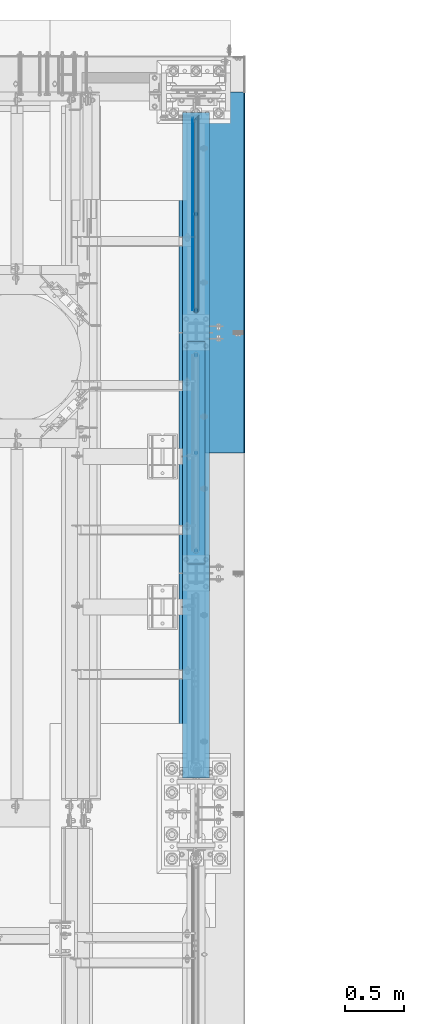
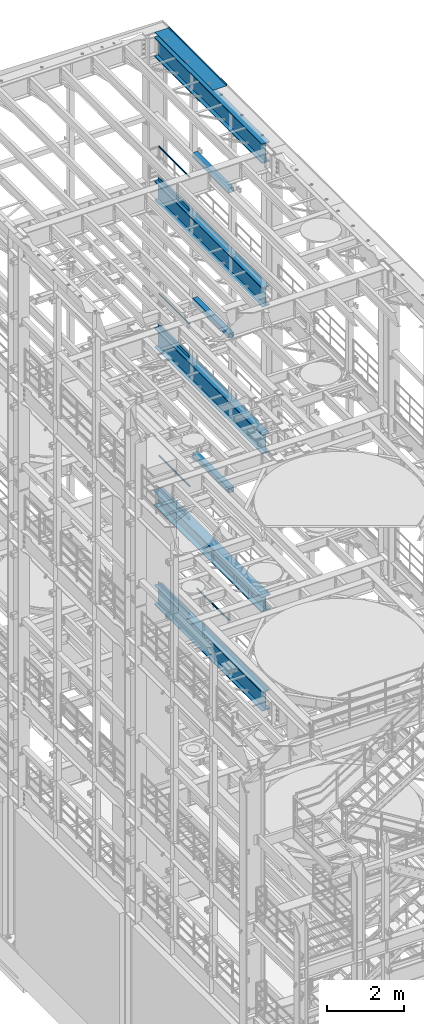
# One storey, part 1078 of 1876: 17 beams, 14 elements without a shape of their own.
"""IFC2X3 building model written with IfcOpenShell, lengths in millimetres."""

from ifc_helpers import new_model, si_unit, frame, origin_with_axes, place, context, subcontext, project, spatial, faceted_brep, material, type_object, element, aggregate, save


model = new_model("IFC2X3")

# Units and contexts
model_context = context("Model", 3, precision=1e-05, world=origin_with_axes())
body_context = subcontext(model_context, "Body", "Model", "MODEL_VIEW")
ifc_project = project(units=[si_unit("LENGTHUNIT", "METRE", prefix="MILLI"), si_unit("AREAUNIT", "SQUARE_METRE"), si_unit("VOLUMEUNIT", "CUBIC_METRE"), si_unit("MASSUNIT", "GRAM", prefix="KILO"), si_unit("TIMEUNIT", "SECOND"), si_unit("PLANEANGLEUNIT", "RADIAN"), si_unit("SOLIDANGLEUNIT", "STERADIAN"), si_unit("THERMODYNAMICTEMPERATUREUNIT", "DEGREE_CELSIUS"), si_unit("LUMINOUSINTENSITYUNIT", "LUMEN")], contexts=[model_context])

# Site, building, storey
site_placement = place(None, origin_with_axes())
site = spatial("IfcSite", under=ifc_project, at=site_placement, CompositionType="ELEMENT")
building_placement = place(site_placement, origin_with_axes())
building = spatial("IfcBuilding", under=site, at=building_placement, Name="Undefined", CompositionType="ELEMENT")
storey_placement = place(building_placement, origin_with_axes())
storey = spatial("IfcBuildingStorey", under=building, at=storey_placement, Name="Undefined", CompositionType="ELEMENT", Elevation=0.0)

# Assembly, beam
assembly_1_placement = place(storey_placement, origin_with_axes())
assembly_1 = element("IfcElementAssembly", 1, at=assembly_1_placement, inside=storey, Name="RAIL", AssemblyPlace="NOTDEFINED", PredefinedType="RIGID_FRAME")
ifc_material_1 = material()
beam_type_1 = type_object("IfcBeamType", Name="PIPE1-1/2SCH40", PredefinedType="NOTDEFINED")
beam_1_placement = place(assembly_1_placement, frame((7619.99999999998, 11848.7825, 19059.525), z_axis=(0.0, 0.0, -1.0), x_axis=(0.0, 1.0, 0.0)))
beam_1 = element("IfcBeam", 2, at=beam_1_placement, type_object=beam_type_1, material=ifc_material_1, Name="RAIL", ObjectType="PIPE1-1/2SCH40", context=body_context, shape_type="Brep", body=[
    faceted_brep([(24.1300000000001, -20.4469999999999, 0.0), (34.3535000000002, -17.7076214311803, 10.2235000000001), (1633.21617856882, -17.7076214311801, 10.2235000000001), (1630.4768, -20.4470000000001, 0.0), (41.8376214311802, -10.2235000000001, 17.7076214311819), (1640.7003, -10.2235000000001, 17.7076214311819), (44.5770000000002, 0.0, 20.4470000000001), (1650.9238, 0.0, 20.4470000000001), (41.8376214311802, 10.2235000000001, 17.7076214311819), (1661.1473, 10.2235000000001, 17.7076214311819), (34.3535000000002, 17.7076214311803, 10.2235000000001), (1668.63142143118, 17.7076214311801, 10.2235000000001), (24.1300000000001, 20.4469999999999, 0.0), (1671.3708, 20.4470000000001, 0.0), (13.9065000000001, 17.7076214311803, -10.2235000000001), (1668.63142143118, 17.7076214311801, -10.2235000000001), (6.42237856882002, 10.2235000000001, -17.7076214311819), (1661.1473, 10.2235000000001, -17.7076214311819), (3.68299999999999, 0.0, -20.4470000000001), (1650.9238, 0.0, -20.4470000000001), (6.42237856882002, -10.2235000000001, -17.7076214311819), (1640.7003, -10.2235000000001, -17.7076214311819), (13.9065000000001, -17.7076214311803, -10.2235000000001), (1633.21617856882, -17.7076214311801, -10.2235000000001), (24.1299999999854, -24.1299999999992, 0.0), (12.0650000000064, -20.8971929933177, -12.0649999999987), (1630.02660700668, -20.8971929933186, -12.0649999999987), (1626.7938, -24.1300000000001, 0.0), (3.23280700668147, -12.0650000000001, -20.8971929933177), (1638.8588, -12.0649999999996, -20.8971929933177), (-1.45519152283669e-11, 0.0, -24.130000000001), (1650.9238, 0.0, -24.130000000001), (3.23280700668147, 12.0650000000001, -20.8971929933177), (1662.9888, 12.0649999999996, -20.8971929933177), (12.0650000000064, 20.8971929933177, -12.0649999999987), (1671.82099299332, 20.8971929933186, -12.0649999999987), (24.1300000000047, 24.1299999999992, 0.0), (1675.0538, 24.1300000000001, 0.0), (36.1949999999997, 20.8971929933184, 12.0649999999987), (1671.82099299332, 20.8971929933186, 12.0649999999987), (45.0271929933187, 12.0650000000001, 20.8971929933177), (1662.9888, 12.0649999999996, 20.8971929933177), (48.2600000000002, 0.0, 24.130000000001), (1650.9238, 0.0, 24.130000000001), (45.0271929933187, -12.0650000000001, 20.8971929933177), (1638.8588, -12.0649999999996, 20.8971929933177), (36.1949999999997, -20.8971929933184, 12.0649999999987), (1630.02660700668, -20.8971929933186, 12.0649999999987)], [[[0, 1, 2, 3]], [[1, 4, 5, 2]], [[4, 6, 7, 5]], [[6, 8, 9, 7]], [[8, 10, 11, 9]], [[10, 12, 13, 11]], [[12, 14, 15, 13]], [[14, 16, 17, 15]], [[16, 18, 19, 17]], [[18, 20, 21, 19]], [[20, 22, 23, 21]], [[22, 0, 3, 23]], [[24, 25, 26, 27]], [[25, 28, 29, 26]], [[28, 30, 31, 29]], [[30, 32, 33, 31]], [[32, 34, 35, 33]], [[34, 36, 37, 35]], [[36, 38, 39, 37]], [[38, 40, 41, 39]], [[40, 42, 43, 41]], [[42, 44, 45, 43]], [[44, 46, 47, 45]], [[46, 24, 27, 47]], [[29, 31, 33, 35, 37, 39, 41, 43, 45, 47, 27, 26], [5, 7, 9, 11, 13, 15, 17, 19, 21, 23, 3, 2]], [[46, 44, 42, 40, 38, 36, 34, 32, 30, 28, 25, 24], [22, 20, 18, 16, 14, 12, 10, 8, 6, 4, 1, 0]]]),
])

assembly_2_placement = place(storey_placement, origin_with_axes())
assembly_2 = element("IfcElementAssembly", 3, at=assembly_2_placement, inside=storey, Name="RAIL", AssemblyPlace="NOTDEFINED", PredefinedType="RIGID_FRAME")
beam_2_placement = place(assembly_2_placement, frame((7619.99999999997, 11848.7825, 14385.925), z_axis=(0.0, 0.0, -1.0), x_axis=(0.0, 1.0, 0.0)))
beam_2 = element("IfcBeam", 4, at=beam_2_placement, type_object=beam_type_1, material=ifc_material_1, Name="RAIL", ObjectType="PIPE1-1/2SCH40", context=body_context, shape_type="Brep", body=[
    faceted_brep([(24.1300000000001, -20.4469999999999, 0.0), (34.3535000000002, -17.7076214311803, 10.2235000000001), (1633.21617856882, -17.7076214311801, 10.2235000000001), (1630.4768, -20.4470000000001, 0.0), (41.8376214311802, -10.2235000000001, 17.7076214311819), (1640.7003, -10.2235000000001, 17.7076214311819), (44.5770000000002, 0.0, 20.4470000000001), (1650.9238, 0.0, 20.4470000000001), (41.8376214311802, 10.2235000000001, 17.7076214311819), (1661.1473, 10.2235000000001, 17.7076214311819), (34.3535000000002, 17.7076214311803, 10.2235000000001), (1668.63142143118, 17.7076214311801, 10.2235000000001), (24.1300000000001, 20.4469999999999, 0.0), (1671.3708, 20.4470000000001, 0.0), (13.9065000000001, 17.7076214311803, -10.2235000000001), (1668.63142143118, 17.7076214311801, -10.2235000000001), (6.42237856882002, 10.2235000000001, -17.7076214311819), (1661.1473, 10.2235000000001, -17.7076214311819), (3.68299999999999, 0.0, -20.4470000000001), (1650.9238, 0.0, -20.4470000000001), (6.42237856882002, -10.2235000000001, -17.7076214311819), (1640.7003, -10.2235000000001, -17.7076214311819), (13.9065000000001, -17.7076214311803, -10.2235000000001), (1633.21617856882, -17.7076214311801, -10.2235000000001), (24.1299999999854, -24.1299999999992, 0.0), (12.0650000000064, -20.8971929933177, -12.0649999999987), (1630.02660700668, -20.8971929933186, -12.0649999999987), (1626.7938, -24.1300000000001, 0.0), (3.23280700668147, -12.0650000000001, -20.8971929933177), (1638.8588, -12.0649999999996, -20.8971929933177), (-1.45519152283669e-11, 0.0, -24.130000000001), (1650.9238, 0.0, -24.130000000001), (3.23280700668147, 12.0650000000001, -20.8971929933177), (1662.9888, 12.0649999999996, -20.8971929933177), (12.0650000000064, 20.8971929933177, -12.0649999999987), (1671.82099299332, 20.8971929933186, -12.0649999999987), (24.1300000000047, 24.1299999999992, 0.0), (1675.0538, 24.1300000000001, 0.0), (36.1949999999997, 20.8971929933184, 12.0649999999987), (1671.82099299332, 20.8971929933186, 12.0649999999987), (45.0271929933187, 12.0650000000001, 20.8971929933177), (1662.9888, 12.0649999999996, 20.8971929933177), (48.2600000000002, 0.0, 24.130000000001), (1650.9238, 0.0, 24.130000000001), (45.0271929933187, -12.0650000000001, 20.8971929933177), (1638.8588, -12.0649999999996, 20.8971929933177), (36.1949999999997, -20.8971929933184, 12.0649999999987), (1630.02660700668, -20.8971929933186, 12.0649999999987)], [[[0, 1, 2, 3]], [[1, 4, 5, 2]], [[4, 6, 7, 5]], [[6, 8, 9, 7]], [[8, 10, 11, 9]], [[10, 12, 13, 11]], [[12, 14, 15, 13]], [[14, 16, 17, 15]], [[16, 18, 19, 17]], [[18, 20, 21, 19]], [[20, 22, 23, 21]], [[22, 0, 3, 23]], [[24, 25, 26, 27]], [[25, 28, 29, 26]], [[28, 30, 31, 29]], [[30, 32, 33, 31]], [[32, 34, 35, 33]], [[34, 36, 37, 35]], [[36, 38, 39, 37]], [[38, 40, 41, 39]], [[40, 42, 43, 41]], [[42, 44, 45, 43]], [[44, 46, 47, 45]], [[46, 24, 27, 47]], [[29, 31, 33, 35, 37, 39, 41, 43, 45, 47, 27, 26], [5, 7, 9, 11, 13, 15, 17, 19, 21, 23, 3, 2]], [[46, 44, 42, 40, 38, 36, 34, 32, 30, 28, 25, 24], [22, 20, 18, 16, 14, 12, 10, 8, 6, 4, 1, 0]]]),
])

assembly_3_placement = place(storey_placement, origin_with_axes())
assembly_3 = element("IfcElementAssembly", 5, at=assembly_3_placement, inside=storey, Name="RAIL", AssemblyPlace="NOTDEFINED", PredefinedType="RIGID_FRAME")
beam_3_placement = place(assembly_3_placement, frame((7619.99999999997, 11848.7825, 9229.725), z_axis=(0.0, 0.0, -1.0), x_axis=(0.0, 1.0, 0.0)))
beam_3 = element("IfcBeam", 6, at=beam_3_placement, type_object=beam_type_1, material=ifc_material_1, Name="RAIL", ObjectType="PIPE1-1/2SCH40", context=body_context, shape_type="Brep", body=[
    faceted_brep([(24.1300000000001, -20.4469999999999, 0.0), (34.3535000000002, -17.7076214311803, 10.2235000000001), (1633.21617856882, -17.7076214311801, 10.2235000000001), (1630.4768, -20.4470000000001, 0.0), (41.8376214311802, -10.2235000000001, 17.7076214311819), (1640.7003, -10.2235000000001, 17.7076214311819), (44.5770000000002, 0.0, 20.4470000000001), (1650.9238, 0.0, 20.4470000000001), (41.8376214311802, 10.2235000000001, 17.7076214311819), (1661.1473, 10.2235000000001, 17.7076214311819), (34.3535000000002, 17.7076214311803, 10.2235000000001), (1668.63142143118, 17.7076214311801, 10.2235000000001), (24.1300000000001, 20.4469999999999, 0.0), (1671.3708, 20.4470000000001, 0.0), (13.9065000000001, 17.7076214311803, -10.2235000000001), (1668.63142143118, 17.7076214311801, -10.2235000000001), (6.42237856882002, 10.2235000000001, -17.7076214311819), (1661.1473, 10.2235000000001, -17.7076214311819), (3.68299999999999, 0.0, -20.4470000000001), (1650.9238, 0.0, -20.4470000000001), (6.42237856882002, -10.2235000000001, -17.7076214311819), (1640.7003, -10.2235000000001, -17.7076214311819), (13.9065000000001, -17.7076214311803, -10.2235000000001), (1633.21617856882, -17.7076214311801, -10.2235000000001), (24.1299999999854, -24.1299999999992, 0.0), (12.0650000000064, -20.8971929933177, -12.0649999999987), (1630.02660700668, -20.8971929933186, -12.0649999999987), (1626.7938, -24.1300000000001, 0.0), (3.23280700668147, -12.0650000000001, -20.8971929933177), (1638.8588, -12.0649999999996, -20.8971929933177), (-1.45519152283669e-11, 0.0, -24.130000000001), (1650.9238, 0.0, -24.130000000001), (3.23280700668147, 12.0650000000001, -20.8971929933177), (1662.9888, 12.0649999999996, -20.8971929933177), (12.0650000000064, 20.8971929933177, -12.0649999999987), (1671.82099299332, 20.8971929933186, -12.0649999999987), (24.1300000000047, 24.1299999999992, 0.0), (1675.0538, 24.1300000000001, 0.0), (36.1949999999997, 20.8971929933184, 12.0649999999987), (1671.82099299332, 20.8971929933186, 12.0649999999987), (45.0271929933187, 12.0650000000001, 20.8971929933177), (1662.9888, 12.0649999999996, 20.8971929933177), (48.2600000000002, 0.0, 24.130000000001), (1650.9238, 0.0, 24.130000000001), (45.0271929933187, -12.0650000000001, 20.8971929933177), (1638.8588, -12.0649999999996, 20.8971929933177), (36.1949999999997, -20.8971929933184, 12.0649999999987), (1630.02660700668, -20.8971929933186, 12.0649999999987)], [[[0, 1, 2, 3]], [[1, 4, 5, 2]], [[4, 6, 7, 5]], [[6, 8, 9, 7]], [[8, 10, 11, 9]], [[10, 12, 13, 11]], [[12, 14, 15, 13]], [[14, 16, 17, 15]], [[16, 18, 19, 17]], [[18, 20, 21, 19]], [[20, 22, 23, 21]], [[22, 0, 3, 23]], [[24, 25, 26, 27]], [[25, 28, 29, 26]], [[28, 30, 31, 29]], [[30, 32, 33, 31]], [[32, 34, 35, 33]], [[34, 36, 37, 35]], [[36, 38, 39, 37]], [[38, 40, 41, 39]], [[40, 42, 43, 41]], [[42, 44, 45, 43]], [[44, 46, 47, 45]], [[46, 24, 27, 47]], [[29, 31, 33, 35, 37, 39, 41, 43, 45, 47, 27, 26], [5, 7, 9, 11, 13, 15, 17, 19, 21, 23, 3, 2]], [[46, 44, 42, 40, 38, 36, 34, 32, 30, 28, 25, 24], [22, 20, 18, 16, 14, 12, 10, 8, 6, 4, 1, 0]]]),
])

assembly_4_placement = place(storey_placement, origin_with_axes())
assembly_4 = element("IfcElementAssembly", 7, at=assembly_4_placement, inside=storey, Name="RAIL", AssemblyPlace="NOTDEFINED", PredefinedType="RIGID_FRAME")
beam_4_placement = place(assembly_4_placement, frame((7620.0, 9817.1, 6207.125), z_axis=(0.0, 0.0, -1.0), x_axis=(0.0, 1.0, 0.0)))
beam_4 = element("IfcBeam", 8, at=beam_4_placement, type_object=beam_type_1, material=ifc_material_1, Name="RAIL", ObjectType="PIPE1-1/2SCH40", context=body_context, shape_type="Brep", body=[
    faceted_brep([(24.1300000000001, -20.4469999999999, 0.0), (34.3535000000002, -17.7076214311803, 10.2235000000001), (1667.4465, -17.7076214311801, 10.2235000000001), (1677.67, -20.4470000000001, 0.0), (41.8376214311802, -10.2235000000001, 17.7076214311819), (1659.96237856882, -10.2235000000001, 17.7076214311819), (44.5770000000002, 0.0, 20.4470000000001), (1657.223, 0.0, 20.4470000000001), (41.8376214311802, 10.2235000000001, 17.7076214311819), (1659.96237856882, 10.2235000000001, 17.7076214311819), (34.3535000000002, 17.7076214311803, 10.2235000000001), (1667.4465, 17.7076214311801, 10.2235000000001), (24.1300000000001, 20.4469999999999, 0.0), (1677.67, 20.4470000000001, 0.0), (13.9065000000001, 17.7076214311803, -10.2235000000001), (1687.8935, 17.7076214311801, -10.2235000000001), (6.42237856882002, 10.2235000000001, -17.7076214311819), (1695.37762143118, 10.2235000000001, -17.7076214311819), (3.68299999999999, 0.0, -20.4470000000001), (1698.117, 0.0, -20.4470000000001), (6.42237856882002, -10.2235000000001, -17.7076214311819), (1695.37762143118, -10.2235000000001, -17.7076214311819), (13.9065000000001, -17.7076214311803, -10.2235000000001), (1687.8935, -17.7076214311801, -10.2235000000001), (24.1299999999854, -24.1299999999992, 0.0), (12.0650000000064, -20.8971929933177, -12.0649999999987), (1689.735, -20.8971929933186, -12.0649999999987), (1677.67, -24.1300000000001, 0.0), (3.23280700668147, -12.0650000000001, -20.8971929933177), (1698.56719299332, -12.0649999999996, -20.8971929933177), (-1.45519152283669e-11, 0.0, -24.130000000001), (1701.8, 0.0, -24.130000000001), (3.23280700668147, 12.0650000000001, -20.8971929933177), (1698.56719299332, 12.0649999999996, -20.8971929933177), (12.0650000000064, 20.8971929933177, -12.0649999999987), (1689.735, 20.8971929933186, -12.0649999999987), (24.1300000000047, 24.1299999999992, 0.0), (1677.67, 24.1300000000001, 0.0), (36.1949999999997, 20.8971929933184, 12.0649999999987), (1665.605, 20.8971929933186, 12.0649999999987), (45.0271929933187, 12.0650000000001, 20.8971929933177), (1656.77280700668, 12.0649999999996, 20.8971929933177), (48.2600000000002, 0.0, 24.130000000001), (1653.54, 0.0, 24.130000000001), (45.0271929933187, -12.0650000000001, 20.8971929933177), (1656.77280700668, -12.0649999999996, 20.8971929933177), (36.1949999999997, -20.8971929933184, 12.0649999999987), (1665.605, -20.8971929933186, 12.0649999999987)], [[[0, 1, 2, 3]], [[1, 4, 5, 2]], [[4, 6, 7, 5]], [[6, 8, 9, 7]], [[8, 10, 11, 9]], [[10, 12, 13, 11]], [[12, 14, 15, 13]], [[14, 16, 17, 15]], [[16, 18, 19, 17]], [[18, 20, 21, 19]], [[20, 22, 23, 21]], [[22, 0, 3, 23]], [[24, 25, 26, 27]], [[25, 28, 29, 26]], [[28, 30, 31, 29]], [[30, 32, 33, 31]], [[32, 34, 35, 33]], [[34, 36, 37, 35]], [[36, 38, 39, 37]], [[38, 40, 41, 39]], [[40, 42, 43, 41]], [[42, 44, 45, 43]], [[44, 46, 47, 45]], [[46, 24, 27, 47]], [[29, 31, 33, 35, 37, 39, 41, 43, 45, 47, 27, 26], [5, 7, 9, 11, 13, 15, 17, 19, 21, 23, 3, 2]], [[46, 44, 42, 40, 38, 36, 34, 32, 30, 28, 25, 24], [22, 20, 18, 16, 14, 12, 10, 8, 6, 4, 1, 0]]]),
])
aggregate(assembly_4, [beam_4])

assembly_5_placement = place(storey_placement, origin_with_axes())
assembly_5 = element("IfcElementAssembly", 9, at=assembly_5_placement, inside=storey, Name="BEAM", AssemblyPlace="NOTDEFINED", PredefinedType="RIGID_FRAME")
ifc_material_2 = material()
beam_type_2 = type_object("IfcBeamType", Name="HSS6X6X3/8", PredefinedType="NOTDEFINED")
beam_5_placement = place(assembly_5_placement, frame((7619.99999974511, 9652.0, 19958.05), z_axis=(-1.0, 0.0, 0.0), x_axis=(0.0, 1.0, 0.0)))
beam_5 = element("IfcBeam", 10, at=beam_5_placement, type_object=beam_type_2, material=ifc_material_2, Name="BEAM", ObjectType="HSS6X6X3/8", context=body_context, shape_type="Brep", body=[
    faceted_brep([(76.2000000000007, 66.6749999999993, -66.6750000000002), (76.2000000000007, -66.6749999999993, -66.6750000000002), (1955.8, -66.6749999999993, -66.675), (1955.8, 66.6749999999993, -66.675), (76.2000000000007, -66.6749999999993, 66.6750000000002), (1955.8, -66.6749999999993, 66.675), (76.2000000000007, 66.6749999999993, 66.6750000000002), (1955.8, 66.6749999999993, 66.675), (76.2000000000007, 76.2000000000007, -76.1999999999998), (76.2000000000007, 76.2000000000007, 76.1999999999998), (1955.8, 76.2000000000007, 76.2), (1955.8, 76.2000000000007, -76.2), (76.2000000000007, -76.2000000000007, 76.1999999999998), (1955.8, -76.2000000000007, 76.2), (76.2000000000007, -76.2000000000007, -76.1999999999998), (1955.8, -76.2000000000007, -76.2)], [[[0, 1, 2, 3]], [[1, 4, 5, 2]], [[4, 6, 7, 5]], [[6, 0, 3, 7]], [[8, 9, 10, 11]], [[9, 12, 13, 10]], [[12, 14, 15, 13]], [[14, 8, 11, 15]], [[13, 15, 11, 10], [5, 7, 3, 2]], [[14, 12, 9, 8], [6, 4, 1, 0]]]),
])
aggregate(assembly_5, [beam_5])

assembly_6_placement = place(storey_placement, origin_with_axes())
assembly_6 = element("IfcElementAssembly", 11, at=assembly_6_placement, inside=storey, Name="BEAM", AssemblyPlace="NOTDEFINED", PredefinedType="RIGID_FRAME")
beam_6_placement = place(assembly_6_placement, frame((7620.0, 9652.0, 15335.25), z_axis=(-1.0, 0.0, 0.0), x_axis=(0.0, 1.0, 0.0)))
beam_6 = element("IfcBeam", 12, at=beam_6_placement, type_object=beam_type_2, material=ifc_material_2, Name="BEAM", ObjectType="HSS6X6X3/8", context=body_context, shape_type="Brep", body=[
    faceted_brep([(76.2000000000007, 66.6749999999993, -66.6750000000002), (76.2000000000007, -66.6749999999993, -66.6750000000002), (1955.8, -66.6749999999993, -66.675), (1955.8, 66.6749999999993, -66.675), (76.2000000000007, -66.6749999999993, 66.6750000000002), (1955.8, -66.6749999999993, 66.675), (76.2000000000007, 66.6749999999993, 66.6750000000002), (1955.8, 66.6749999999993, 66.675), (76.2000000000007, 76.2000000000007, -76.1999999999998), (76.2000000000007, 76.2000000000007, 76.1999999999998), (1955.8, 76.2000000000007, 76.2), (1955.8, 76.2000000000007, -76.2), (76.2000000000007, -76.2000000000007, 76.1999999999998), (1955.8, -76.2000000000007, 76.2), (76.2000000000007, -76.2000000000007, -76.1999999999998), (1955.8, -76.2000000000007, -76.2)], [[[0, 1, 2, 3]], [[1, 4, 5, 2]], [[4, 6, 7, 5]], [[6, 0, 3, 7]], [[8, 9, 10, 11]], [[9, 12, 13, 10]], [[12, 14, 15, 13]], [[14, 8, 11, 15]], [[13, 15, 11, 10], [5, 7, 3, 2]], [[14, 12, 9, 8], [6, 4, 1, 0]]]),
])
aggregate(assembly_6, [beam_6])

assembly_7_placement = place(storey_placement, origin_with_axes())
assembly_7 = element("IfcElementAssembly", 13, at=assembly_7_placement, inside=storey, Name="BEAM", AssemblyPlace="NOTDEFINED", PredefinedType="RIGID_FRAME")
beam_7_placement = place(assembly_7_placement, frame((7620.0, 9652.0, 10420.35), z_axis=(-1.0, 0.0, 0.0), x_axis=(0.0, 1.0, 0.0)))
beam_7 = element("IfcBeam", 14, at=beam_7_placement, type_object=beam_type_2, material=ifc_material_2, Name="BEAM", ObjectType="HSS6X6X3/8", context=body_context, shape_type="Brep", body=[
    faceted_brep([(76.2000000000007, 66.6749999999993, -66.6750000000002), (76.2000000000007, -66.6749999999993, -66.6750000000002), (1955.8, -66.6749999999993, -66.675), (1955.8, 66.6749999999993, -66.675), (76.2000000000007, -66.6749999999993, 66.6750000000002), (1955.8, -66.6749999999993, 66.675), (76.2000000000007, 66.6749999999993, 66.6750000000002), (1955.8, 66.6749999999993, 66.675), (76.2000000000007, 76.2000000000007, -76.1999999999998), (76.2000000000007, 76.2000000000007, 76.1999999999998), (1955.8, 76.2000000000007, 76.2), (1955.8, 76.2000000000007, -76.2), (76.2000000000007, -76.2000000000007, 76.1999999999998), (1955.8, -76.2000000000007, 76.2), (76.2000000000007, -76.2000000000007, -76.1999999999998), (1955.8, -76.2000000000007, -76.2)], [[[0, 1, 2, 3]], [[1, 4, 5, 2]], [[4, 6, 7, 5]], [[6, 0, 3, 7]], [[8, 9, 10, 11]], [[9, 12, 13, 10]], [[12, 14, 15, 13]], [[14, 8, 11, 15]], [[13, 15, 11, 10], [5, 7, 3, 2]], [[14, 12, 9, 8], [6, 4, 1, 0]]]),
])
aggregate(assembly_7, [beam_7])

# Beam
ifc_material_3 = material(Name="STEEL/A36")
beam_type_3 = type_object("IfcBeamType", PredefinedType="NOTDEFINED")
beam_8_placement = place(assembly_1_placement, frame((7592.69500000001, 11872.9125, 18049.875), z_axis=(0.0, 0.0, 1.0), x_axis=(0.0, 1.0, 0.0)))
beam_8 = element("IfcBeam", 15, at=beam_8_placement, type_object=beam_type_3, material=ifc_material_3, Name="PLATE", context=body_context, shape_type="Brep", body=[
    faceted_brep([(0.0, 3.17500000000018, -50.8000000000002), (0.0, 3.17500000000018, 50.8000000000002), (1626.7938, 3.175, 50.7999999999993), (1626.7938, 3.175, -50.7999999999993), (0.0, -3.17500000000018, 50.8000000000002), (1626.7938, -3.175, 50.7999999999993), (0.0, -3.17500000000018, -50.8000000000002), (1626.7938, -3.175, -50.7999999999993)], [[[0, 1, 2, 3]], [[1, 4, 5, 2]], [[4, 6, 7, 5]], [[6, 0, 3, 7]], [[5, 7, 3, 2]], [[6, 4, 1, 0]]]),
])

aggregate(assembly_1, [beam_8, beam_1])

beam_9_placement = place(assembly_2_placement, frame((7592.69500000001, 11872.9125, 13376.275), z_axis=(0.0, 0.0, 1.0), x_axis=(0.0, 1.0, 0.0)))
beam_9 = element("IfcBeam", 16, at=beam_9_placement, type_object=beam_type_3, material=ifc_material_3, Name="PLATE", context=body_context, shape_type="Brep", body=[
    faceted_brep([(0.0, 3.17500000000018, -50.8000000000002), (0.0, 3.17500000000018, 50.8000000000002), (1626.7938, 3.175, 50.7999999999993), (1626.7938, 3.175, -50.7999999999993), (0.0, -3.17500000000018, 50.8000000000002), (1626.7938, -3.175, 50.7999999999993), (0.0, -3.17500000000018, -50.8000000000002), (1626.7938, -3.175, -50.7999999999993)], [[[0, 1, 2, 3]], [[1, 4, 5, 2]], [[4, 6, 7, 5]], [[6, 0, 3, 7]], [[5, 7, 3, 2]], [[6, 4, 1, 0]]]),
])

aggregate(assembly_2, [beam_9, beam_2])

beam_10_placement = place(assembly_3_placement, frame((7592.69500000001, 11872.9125, 8220.075), z_axis=(0.0, 0.0, 1.0), x_axis=(0.0, 1.0, 0.0)))
beam_10 = element("IfcBeam", 17, at=beam_10_placement, type_object=beam_type_3, material=ifc_material_3, Name="PLATE", context=body_context, shape_type="Brep", body=[
    faceted_brep([(0.0, 3.17500000000018, -50.8000000000002), (0.0, 3.17500000000018, 50.8000000000002), (1626.7938, 3.175, 50.7999999999993), (1626.7938, 3.175, -50.7999999999993), (0.0, -3.17500000000018, 50.8000000000002), (1626.7938, -3.175, 50.7999999999993), (0.0, -3.17500000000018, -50.8000000000002), (1626.7938, -3.175, -50.7999999999993)], [[[0, 1, 2, 3]], [[1, 4, 5, 2]], [[4, 6, 7, 5]], [[6, 0, 3, 7]], [[5, 7, 3, 2]], [[6, 4, 1, 0]]]),
])

aggregate(assembly_3, [beam_10, beam_3])

# Assembly, beam
assembly_8_placement = place(storey_placement, origin_with_axes())
assembly_8 = element("IfcElementAssembly", 18, at=assembly_8_placement, inside=storey, Name="RAIL", AssemblyPlace="NOTDEFINED", PredefinedType="RIGID_FRAME")
beam_11_placement = place(assembly_8_placement, frame((7592.69500000001, 11872.9125, 5197.475), z_axis=(0.0, 0.0, 1.0), x_axis=(0.0, 1.0, 0.0)))
beam_11 = element("IfcBeam", 19, at=beam_11_placement, type_object=beam_type_3, material=ifc_material_3, Name="PLATE", context=body_context, shape_type="Brep", body=[
    faceted_brep([(0.0, 3.17500000000018, -50.8000000000002), (0.0, 3.17500000000018, 50.8000000000002), (1626.7938, 3.175, 50.7999999999993), (1626.7938, 3.175, -50.7999999999993), (0.0, -3.17500000000018, 50.8000000000002), (1626.7938, -3.175, 50.7999999999993), (0.0, -3.17500000000018, -50.8000000000002), (1626.7938, -3.175, -50.7999999999993)], [[[0, 1, 2, 3]], [[1, 4, 5, 2]], [[4, 6, 7, 5]], [[6, 0, 3, 7]], [[5, 7, 3, 2]], [[6, 4, 1, 0]]]),
])
aggregate(assembly_8, [beam_11])

assembly_9_placement = place(storey_placement, origin_with_axes())
assembly_9 = element("IfcElementAssembly", 20, at=assembly_9_placement, inside=storey, Name="BENT PLATE", AssemblyPlace="NOTDEFINED", PredefinedType="RIGID_FRAME")
beam_type_4 = type_object("IfcBeamType", PredefinedType="NOTDEFINED")
beam_12_placement = place(assembly_9_placement, frame((7619.99998321378, 12192.0, 22558.375), z_axis=(0.0, 1.0, 0.0), x_axis=(0.999999999986024, 0.0, -5.28699999861059e-06)))
beam_12 = element("IfcBeam", 21, at=beam_12_placement, type_object=beam_type_4, material=ifc_material_3, Name="BENT PLATE", context=body_context, shape_type="Brep", body=[
    faceted_brep([(9.877112461254e-10, -3.17499999999563, -1524.0), (9.877112461254e-10, -3.17499999999563, 1524.0), (-9.88620740827173e-10, 3.17500000000291, 1524.0), (-9.88620740827173e-10, 3.17500000000291, -1524.0), (412.74996162189, 3.17499999736538, 1524.0), (412.74996162189, 3.17499999736538, -1524.0), (406.399963385245, -3.17500000258951, -1524.0), (406.399963385245, -3.17500000258951, 1524.0), (412.749980137296, -63.5005721684938, 1524.0), (412.749980137296, -63.5005721684938, -1524.0), (406.399980137296, -63.5005739318367, 1524.0), (406.399980137296, -63.5005739318367, -1524.0)], [[[0, 1, 2, 3]], [[3, 2, 4, 5]], [[1, 0, 6, 7]], [[5, 4, 8, 9]], [[4, 2, 1, 7, 10, 8]], [[7, 6, 11, 10]], [[6, 0, 3, 5, 9, 11]], [[10, 11, 9, 8]]]),
])
aggregate(assembly_9, [beam_12])

assembly_10_placement = place(storey_placement, origin_with_axes())
assembly_10 = element("IfcElementAssembly", 22, at=assembly_10_placement, inside=storey, Name="BEAM", AssemblyPlace="NOTDEFINED", PredefinedType="RIGID_FRAME")
ifc_material_4 = material(Name="STEEL/A992")
beam_type_5 = type_object("IfcBeamType", Name="W24X103", PredefinedType="NOTDEFINED")
beam_13_placement = place(assembly_10_placement, frame((7620.0, 7620.0, 17672.05), z_axis=(0.0, 0.0, 1.0), x_axis=(0.0, 1.0, 0.0)))
beam_13 = element("IfcBeam", 23, at=beam_13_placement, type_object=beam_type_5, material=ifc_material_4, Name="BEAM", ObjectType="W24X103", context=body_context, shape_type="Brep", body=[
    faceted_brep([(301.625, -114.3, -285.75), (301.625, -114.3, -311.150000000001), (5922.9625, -114.3, -311.150000000001), (5922.9625, -114.3, -285.75), (301.625, -7.14375000000018, -285.75), (5922.9625, -7.14375000000018, -285.75), (301.625, -7.14375000000018, 285.75), (5922.9625, -7.14375000000018, 285.75), (301.625, -114.3, 285.75), (5922.9625, -114.3, 285.75), (301.625, -114.3, 311.150000000001), (5922.9625, -114.3, 311.150000000001), (301.625, 114.3, 311.150000000001), (5922.9625, 114.3, 311.150000000001), (301.625, 114.3, 285.75), (5922.9625, 114.3, 285.75), (301.625, 7.14375000000018, 285.75), (5922.9625, 7.14375000000018, 285.75), (301.625, 7.14375000000018, -285.75), (5922.9625, 7.14375000000018, -285.75), (301.625, 114.3, -285.75), (5922.9625, 114.3, -285.75), (301.625, 114.3, -311.150000000001), (5922.9625, 114.3, -311.150000000001)], [[[0, 1, 2, 3]], [[4, 0, 3, 5]], [[6, 4, 5, 7]], [[8, 6, 7, 9]], [[10, 8, 9, 11]], [[12, 10, 11, 13]], [[14, 12, 13, 15]], [[16, 14, 15, 17]], [[18, 16, 17, 19]], [[20, 18, 19, 21]], [[1, 0, 4, 6, 8, 10, 12, 14, 16, 18, 20, 22]], [[1, 22, 23, 2]], [[19, 17, 15, 13, 11, 9, 7, 5, 3, 2, 23, 21]], [[22, 20, 21, 23]]]),
])
aggregate(assembly_10, [beam_13])

assembly_11_placement = place(storey_placement, origin_with_axes())
assembly_11 = element("IfcElementAssembly", 24, at=assembly_11_placement, inside=storey, Name="BEAM", AssemblyPlace="NOTDEFINED", PredefinedType="RIGID_FRAME")
beam_14_placement = place(assembly_11_placement, frame((7620.0, 7620.0, 12998.45), z_axis=(0.0, 0.0, 1.0), x_axis=(0.0, 1.0, 0.0)))
beam_14 = element("IfcBeam", 25, at=beam_14_placement, type_object=beam_type_5, material=ifc_material_4, Name="BEAM", ObjectType="W24X103", context=body_context, shape_type="Brep", body=[
    faceted_brep([(301.625, -114.3, -285.75), (301.625, -114.3, -311.150000000001), (5922.9625, -114.3, -311.150000000001), (5922.9625, -114.3, -285.75), (301.625, -7.14375000000018, -285.75), (5922.9625, -7.14375000000018, -285.75), (301.625, -7.14375000000018, 285.75), (5922.9625, -7.14375000000018, 285.75), (301.625, -114.3, 285.75), (5922.9625, -114.3, 285.75), (301.625, -114.3, 311.150000000001), (5922.9625, -114.3, 311.150000000001), (301.625, 114.3, 311.150000000001), (5922.9625, 114.3, 311.150000000001), (301.625, 114.3, 285.75), (5922.9625, 114.3, 285.75), (301.625, 7.14375000000018, 285.75), (5922.9625, 7.14375000000018, 285.75), (301.625, 7.14375000000018, -285.75), (5922.9625, 7.14375000000018, -285.75), (301.625, 114.3, -285.75), (5922.9625, 114.3, -285.75), (301.625, 114.3, -311.150000000001), (5922.9625, 114.3, -311.150000000001)], [[[0, 1, 2, 3]], [[4, 0, 3, 5]], [[6, 4, 5, 7]], [[8, 6, 7, 9]], [[10, 8, 9, 11]], [[12, 10, 11, 13]], [[14, 12, 13, 15]], [[16, 14, 15, 17]], [[18, 16, 17, 19]], [[20, 18, 19, 21]], [[1, 0, 4, 6, 8, 10, 12, 14, 16, 18, 20, 22]], [[1, 22, 23, 2]], [[19, 17, 15, 13, 11, 9, 7, 5, 3, 2, 23, 21]], [[22, 20, 21, 23]]]),
])
aggregate(assembly_11, [beam_14])

assembly_12_placement = place(storey_placement, origin_with_axes())
assembly_12 = element("IfcElementAssembly", 26, at=assembly_12_placement, inside=storey, Name="BEAM", AssemblyPlace="NOTDEFINED", PredefinedType="RIGID_FRAME")
beam_15_placement = place(assembly_12_placement, frame((7620.0, 7620.0, 22244.05), z_axis=(0.0, 0.0, 1.0), x_axis=(0.0, 1.0, 0.0)))
beam_15 = element("IfcBeam", 27, at=beam_15_placement, type_object=beam_type_5, material=ifc_material_4, Name="BEAM", ObjectType="W24X103", context=body_context, shape_type="Brep", body=[
    faceted_brep([(301.625, -114.3, -285.75), (301.625, -114.3, -311.150000000001), (5922.9625, -114.3, -311.150000000001), (5922.9625, -114.3, -285.75), (301.625, -7.14375000000018, -285.75), (5922.9625, -7.14375000000018, -285.75), (301.625, -7.14375000000018, 285.75), (5922.9625, -7.14375000000018, 285.75), (301.625, -114.3, 285.75), (5922.9625, -114.3, 285.75), (301.625, -114.3, 311.150000000001), (5922.9625, -114.3, 311.150000000001), (301.625, 114.3, 311.150000000001), (5922.9625, 114.3, 311.150000000001), (301.625, 114.3, 285.75), (5922.9625, 114.3, 285.75), (301.625, 7.14375000000018, 285.75), (5922.9625, 7.14375000000018, 285.75), (301.625, 7.14375000000018, -285.75), (5922.9625, 7.14375000000018, -285.75), (301.625, 114.3, -285.75), (5922.9625, 114.3, -285.75), (301.625, 114.3, -311.150000000001), (5922.9625, 114.3, -311.150000000001)], [[[0, 1, 2, 3]], [[4, 0, 3, 5]], [[6, 4, 5, 7]], [[8, 6, 7, 9]], [[10, 8, 9, 11]], [[12, 10, 11, 13]], [[14, 12, 13, 15]], [[16, 14, 15, 17]], [[18, 16, 17, 19]], [[20, 18, 19, 21]], [[1, 0, 4, 6, 8, 10, 12, 14, 16, 18, 20, 22]], [[1, 22, 23, 2]], [[19, 17, 15, 13, 11, 9, 7, 5, 3, 2, 23, 21]], [[22, 20, 21, 23]]]),
])
aggregate(assembly_12, [beam_15])

assembly_13_placement = place(storey_placement, origin_with_axes())
assembly_13 = element("IfcElementAssembly", 28, at=assembly_13_placement, inside=storey, Name="BEAM", AssemblyPlace="NOTDEFINED", PredefinedType="RIGID_FRAME")
beam_16_placement = place(assembly_13_placement, frame((7620.0, 7620.0, 4819.65), z_axis=(0.0, 0.0, 1.0), x_axis=(0.0, 1.0, 0.0)))
beam_16 = element("IfcBeam", 29, at=beam_16_placement, type_object=beam_type_5, material=ifc_material_4, Name="BEAM", ObjectType="W24X103", context=body_context, shape_type="Brep", body=[
    faceted_brep([(301.625, -114.3, -285.75), (301.625, -114.3, -311.150000000001), (5922.9625, -114.3, -311.150000000001), (5922.9625, -114.3, -285.75), (301.625, -7.14375000000018, -285.75), (5922.9625, -7.14375000000018, -285.75), (301.625, -7.14375000000018, 285.75), (5922.9625, -7.14375000000018, 285.75), (301.625, -114.3, 285.75), (5922.9625, -114.3, 285.75), (301.625, -114.3, 311.150000000001), (5922.9625, -114.3, 311.150000000001), (301.625, 114.3, 311.150000000001), (5922.9625, 114.3, 311.150000000001), (301.625, 114.3, 285.75), (5922.9625, 114.3, 285.75), (301.625, 7.14375000000018, 285.75), (5922.9625, 7.14375000000018, 285.75), (301.625, 7.14375000000018, -285.75), (5922.9625, 7.14375000000018, -285.75), (301.625, 114.3, -285.75), (5922.9625, 114.3, -285.75), (301.625, 114.3, -311.150000000001), (5922.9625, 114.3, -311.150000000001)], [[[0, 1, 2, 3]], [[4, 0, 3, 5]], [[6, 4, 5, 7]], [[8, 6, 7, 9]], [[10, 8, 9, 11]], [[12, 10, 11, 13]], [[14, 12, 13, 15]], [[16, 14, 15, 17]], [[18, 16, 17, 19]], [[20, 18, 19, 21]], [[1, 0, 4, 6, 8, 10, 12, 14, 16, 18, 20, 22]], [[1, 22, 23, 2]], [[19, 17, 15, 13, 11, 9, 7, 5, 3, 2, 23, 21]], [[22, 20, 21, 23]]]),
])
aggregate(assembly_13, [beam_16])

assembly_14_placement = place(storey_placement, origin_with_axes())
assembly_14 = element("IfcElementAssembly", 30, at=assembly_14_placement, inside=storey, Name="BEAM", AssemblyPlace="NOTDEFINED", PredefinedType="RIGID_FRAME")
beam_type_6 = type_object("IfcBeamType", Name="W18X106", PredefinedType="NOTDEFINED")
beam_17_placement = place(assembly_14_placement, frame((7620.0, 7620.0, 7915.275), z_axis=(0.0, 0.0, 1.0), x_axis=(0.0, 1.0, 0.0)))
beam_17 = element("IfcBeam", 31, at=beam_17_placement, type_object=beam_type_6, material=ifc_material_4, Name="BEAM", ObjectType="W18X106", context=body_context, shape_type="Brep", body=[
    faceted_brep([(301.625, -142.875, -214.3125), (301.625, -142.875, -238.125), (5922.9625, -142.875, -238.125), (5922.9625, -142.875, -214.3125), (301.625, -7.14375000000018, -214.3125), (5922.9625, -7.14375000000018, -214.3125), (301.625, -7.14375000000018, 214.3125), (5922.9625, -7.14375000000018, 214.3125), (301.625, -142.875, 214.3125), (5922.9625, -142.875, 214.3125), (301.625, -142.875, 238.125), (5922.9625, -142.875, 238.125), (301.625, 142.875, 238.125), (5922.9625, 142.875, 238.125), (301.625, 142.875, 214.3125), (5922.9625, 142.875, 214.3125), (301.625, 7.14375000000018, 214.3125), (5922.9625, 7.14375000000018, 214.3125), (301.625, 7.14375000000018, -214.3125), (5922.9625, 7.14375000000018, -214.3125), (301.625, 142.875, -214.3125), (5922.9625, 142.875, -214.3125), (301.625, 142.875, -238.125), (5922.9625, 142.875, -238.125)], [[[0, 1, 2, 3]], [[4, 0, 3, 5]], [[6, 4, 5, 7]], [[8, 6, 7, 9]], [[10, 8, 9, 11]], [[12, 10, 11, 13]], [[14, 12, 13, 15]], [[16, 14, 15, 17]], [[18, 16, 17, 19]], [[20, 18, 19, 21]], [[1, 0, 4, 6, 8, 10, 12, 14, 16, 18, 20, 22]], [[1, 22, 23, 2]], [[19, 17, 15, 13, 11, 9, 7, 5, 3, 2, 23, 21]], [[22, 20, 21, 23]]]),
])
aggregate(assembly_14, [beam_17])

save(model, "model.ifc")
